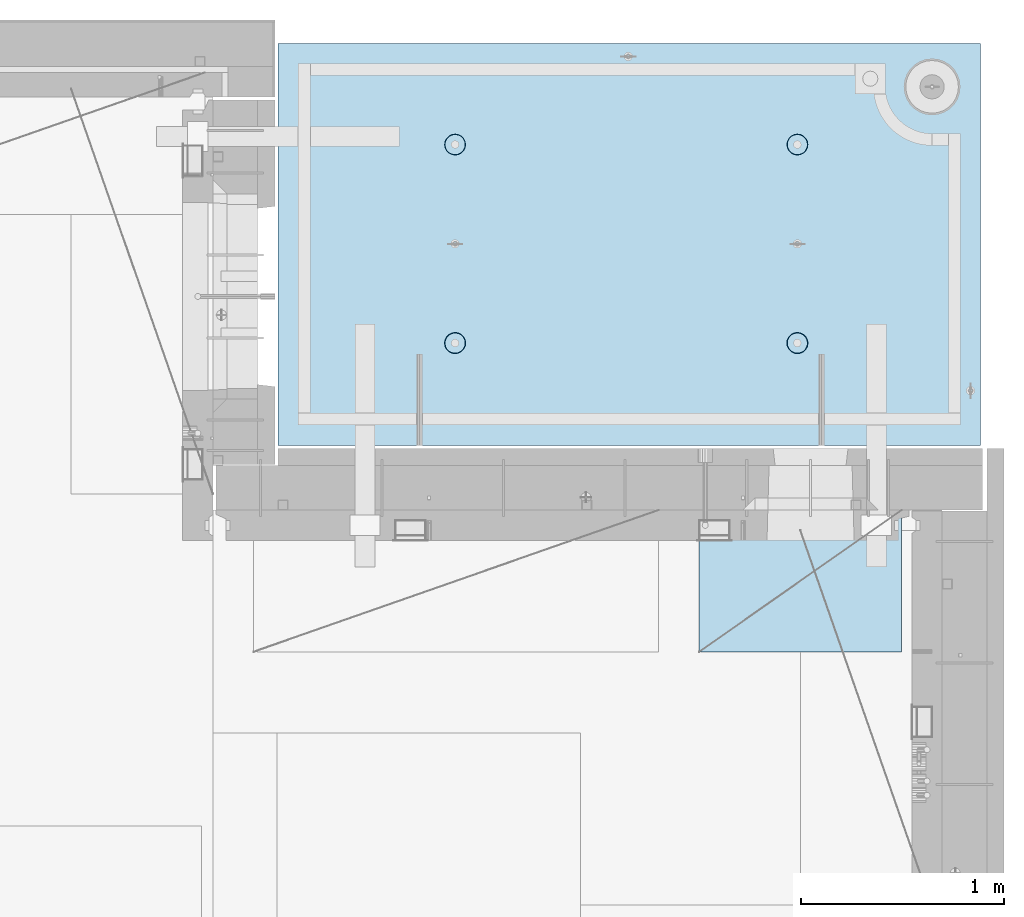
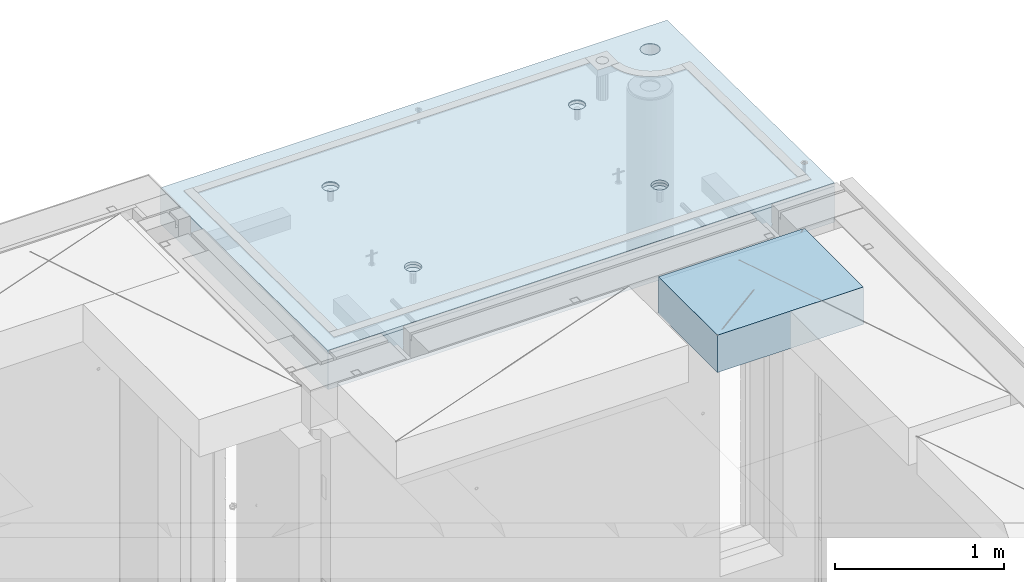
# One storey, part 203 of 341: 2 slabs, 1 plate, 2 elements without a shape of their own.
"""IFC2X3 building model written with IfcOpenShell, lengths in millimetres."""

from ifc_helpers import new_model, si_unit, frame, origin_with_axes, place, context, subcontext, project, spatial, faceted_brep, material, type_object, element, aggregate, save


model = new_model("IFC2X3")

# Units and contexts
model_context = context("Model", 3, precision=1e-05, world=origin_with_axes())
body_context = subcontext(model_context, "Body", "Model", "MODEL_VIEW")
ifc_project = project(units=[si_unit("LENGTHUNIT", "METRE", prefix="MILLI"), si_unit("AREAUNIT", "SQUARE_METRE"), si_unit("VOLUMEUNIT", "CUBIC_METRE"), si_unit("MASSUNIT", "GRAM", prefix="KILO"), si_unit("TIMEUNIT", "SECOND"), si_unit("PLANEANGLEUNIT", "RADIAN"), si_unit("SOLIDANGLEUNIT", "STERADIAN"), si_unit("THERMODYNAMICTEMPERATUREUNIT", "DEGREE_CELSIUS"), si_unit("LUMINOUSINTENSITYUNIT", "LUMEN")], contexts=[model_context])

# Site, building, storey
site_placement = place(None, origin_with_axes())
site = spatial("IfcSite", under=ifc_project, at=site_placement, CompositionType="ELEMENT")
building_placement = place(site_placement, origin_with_axes())
building = spatial("IfcBuilding", under=site, at=building_placement, CompositionType="ELEMENT")
storey_placement = place(building_placement, origin_with_axes())
storey = spatial("IfcBuildingStorey", under=building, at=storey_placement, Name="5", CompositionType="ELEMENT", Elevation=0.0)

# Assembly, slabs
assembly_1_placement = place(storey_placement, origin_with_axes())
assembly_1 = element("IfcElementAssembly", 1, at=assembly_1_placement, inside=storey, AssemblyPlace="NOTDEFINED", PredefinedType="REINFORCEMENT_UNIT")
ifc_material_1 = material(Name="CONCRETE/C35/45")
slab_type_1 = type_object("IfcSlabType", PredefinedType="NOTDEFINED")
slab_1_placement = place(assembly_1_placement, frame((31779.9998568133, 20899.9965573523, 96717.5), z_axis=(0.0, 1.0, 0.0), x_axis=(1.0, 0.0, 0.0)))
slab_1 = element("IfcSlab", 2, at=slab_1_placement, type_object=slab_type_1, material=ifc_material_1, PredefinedType="FLOOR", context=body_context, shape_type="Brep", body=[
    faceted_brep([(3287.06232936882, 9.55874156874779, 1751.46731182328), (3287.06232936882, 12.4999999999563, 1751.46731182328), (3278.5399580536, 12.4999999999563, 1734.74121634823), (3278.5399580536, 9.3480858430994, 1734.74121634823), (3265.26605352866, 12.4999999999563, 1721.46731182328), (3265.26605352866, 9.18090851265879, 1721.46731182328), (3248.5399580536, 12.4999999999563, 1712.94494050807), (3248.5399580536, 9.07357405936637, 1712.94494050807), (3229.99893839111, 12.4999999999563, 1710.00833148578), (3229.99893839111, 9.03658912732499, 1710.00833148578), (3211.45791872861, 12.4999999999563, 1712.94494050807), (3211.45791872861, 9.07357405936637, 1712.94494050807), (3194.73182325356, 12.4999999999563, 1721.46731182328), (3194.73182325356, 9.18090851267334, 1721.46731182328), (3181.45791872861, 12.4999999999563, 1734.74121634823), (3181.45791872861, 9.3480858430994, 1734.74121634823), (3172.9355474134, 12.4999999999563, 1751.46731182328), (3172.9355474134, 9.55874156874779, 1751.46731182328), (3169.99893839111, 12.4999999999563, 1770.00833148578), (3169.99893839111, 9.79225523948844, 1770.00833148578), (3172.9355474134, 12.4999999999563, 1788.54935114827), (3172.9355474134, 10.0257689102291, 1788.54935114827), (3181.45791872861, 12.4999999999563, 1805.27544662332), (3181.45791872861, 10.236424635892, 1805.27544662332), (3194.73182325356, 12.4999999999563, 1818.54935114827), (3194.73182325356, 10.4036019663181, 1818.54935114827), (3211.45791872861, 12.4999999999563, 1827.07172246349), (3211.45791872861, 10.5109364196105, 1827.07172246349), (3229.99893839111, 12.4999999999563, 1830.00833148578), (3229.99893839111, 10.5479213516664, 1830.00833148578), (3248.5399580536, 12.4999999999563, 1827.07172246349), (3248.5399580536, 10.5109364196105, 1827.07172246349), (3265.26605352866, 12.4999999999563, 1818.54935114827), (3265.26605352866, 10.4036019663181, 1818.54935114827), (3278.5399580536, 12.4999999999563, 1805.27544662332), (3278.5399580536, 10.2364246358775, 1805.27544662332), (3287.06232936882, 12.4999999999563, 1788.54935114827), (3287.06232936882, 10.0257689102291, 1788.54935114827), (3289.99893839111, 12.4999999999563, 1770.00833148578), (3289.99893839111, 9.79225523948844, 1770.00833148578), (7.41420080885291e-08, 12.4999999999927, 0.0), (-7.41420080885291e-08, -12.5, -3.63797880709171e-12), (0.0, 12.5, 1985.00366210938), (3470.0, 12.5, 0.0), (3470.00000000004, 12.4999999999563, 1985.00366210935), (3470.0, -12.5, 0.0), (2614.71871715545, -5.93617388149141, 521.168755308547), (2613.67503600632, 12.4999999999709, 520.829642746605), (2616.18047624359, 12.4999999999709, 505.010915653602), (2617.28998057371, -6.13967274603783, 505.010915653602), (2607.28293696061, -5.7526757610467, 535.738532951145), (2606.40396524136, 12.4999999999709, 535.099922616191), (2595.7125242481, -5.60710538028798, 547.296842506817), (2595.0790070157, 12.4999999999709, 546.424880841845), (2581.14006820649, -5.51366887726181, 554.715714533479), (2580.80872714612, 12.4999999999709, 553.695951606805), (2564.99000005311, -5.48147745869937, 557.271717883286), (2564.99000005311, 12.4999999999709, 556.201391844079), (2548.83993189974, -5.51366887726181, 554.715714533479), (2549.17127296011, 12.4999999999709, 553.695951606805), (2534.26747585813, -5.60710538028798, 547.296842506817), (2534.90099309052, 12.4999999999709, 546.424880841845), (2522.69706314561, -5.75267576103215, 535.738532951145), (2523.57603486487, 12.4999999999709, 535.099922616191), (2515.26128295077, -5.93617388147686, 521.168755308547), (2516.30496409991, 12.4999999999709, 520.829642746605), (2512.69001953251, -6.13967274603783, 505.010915653602), (2513.79952386263, 12.4999999999709, 505.010915653602), (2515.23823726424, -6.34326591769059, 488.84558800119), (2516.30496409991, 12.4999999999709, 489.192188560599), (2522.65977443627, -6.52701093736687, 474.256206522903), (2523.57603486487, 12.4999999999709, 474.921908691009), (2534.2301871423, -6.67288650246337, 462.673665286093), (2534.90099309052, 12.4999999999709, 463.596950465359), (2548.81688620273, -6.76656990486663, 455.235189411429), (2549.17127296011, 12.4999999999709, 456.325879700398), (2564.99000005311, -6.79885563062271, 452.67169805654), (2564.99000005311, 12.4999999999709, 453.820439463125), (2581.16311390349, -6.76656990486663, 455.235189411429), (2580.80872714612, 12.4999999999709, 456.325879700398), (2595.74981296392, -6.67288650246337, 462.673665286093), (2595.07900701571, 12.4999999999709, 463.596950465359), (2607.32022566996, -6.52701093736687, 474.256206522903), (2606.40396524136, 12.4999999999709, 474.921908691009), (2614.74176284199, -6.34326591769059, 488.84558800119), (2613.67503600632, 12.4999999999709, 489.192188560599), (924.718717121814, -5.93617388307757, 521.168755181017), (923.675035972585, 12.4999999999854, 520.829642619046), (926.180476209858, 12.4999999999854, 505.010915526043), (927.289980540074, -6.13967274762399, 505.010915526043), (917.282936926953, -5.75267576263286, 535.738532823641), (916.403965207624, 12.4999999999854, 535.099922488633), (905.712524214421, -5.60710538187413, 547.296842379335), (905.07900698197, 12.4999999999854, 546.424880714287), (891.140068172776, -5.51366887886252, 554.715714406011), (890.808727112384, 12.4999999999854, 553.695951479247), (874.990000019381, -5.48147746030008, 557.271717755822), (874.990000019381, 12.4999999999854, 556.20139171652), (858.839931865987, -5.51366887886252, 554.715714406011), (859.171272926378, 12.4999999999854, 553.695951479247), (844.267475824341, -5.60710538187413, 547.296842379335), (844.900993056792, 12.4999999999854, 546.424880714287), (832.697063111809, -5.75267576263286, 535.738532823641), (833.576034831138, 12.4999999999854, 535.099922488633), (825.261282916948, -5.93617388307757, 521.168755181017), (826.304964066177, 12.4999999999854, 520.829642619046), (822.690019498688, -6.13967274762399, 505.010915526043), (823.799523828904, 12.4999999999854, 505.010915526043), (825.238237230413, -6.34326591927675, 488.845587873602), (826.304964066174, 12.4999999999854, 489.19218843304), (832.659774402466, -6.52701093895303, 474.25620639529), (833.576034831141, 12.4999999999854, 474.921908563454), (844.230187108518, -6.67288650404953, 462.673665158458), (844.900993056788, 12.4999999999854, 463.5969503378), (858.816886168974, -6.76656990646734, 455.23518928378), (859.171272926378, 12.4999999999854, 456.32587957284), (874.990000019381, -6.79885563222342, 452.671697928887), (874.990000019381, 12.4999999999854, 453.820439335566), (891.163113869789, -6.76656990646734, 455.23518928378), (890.808727112384, 12.4999999999854, 456.32587957284), (905.749812930244, -6.67288650404953, 462.673665158458), (905.079006981974, 12.4999999999854, 463.5969503378), (917.320225636297, -6.52701093895303, 474.25620639529), (916.403965207621, 12.4999999999854, 474.921908563454), (924.741762808349, -6.34326591927675, 488.845587873602), (923.675035972588, 12.4999999999854, 489.19218843304), (924.02016693788, 6.4034111394576, 1500.93361352766), (923.67503595199, 12.4999999999854, 1500.82147367257), (926.18047618926, 12.4999999999854, 1485.00274657956), (926.555311256641, 6.20277086795249, 1485.00274657956), (916.688838773403, 6.58433162167785, 1515.29872631776), (916.403965187026, 12.4999999999854, 1515.09175354215), (905.280958178348, 6.7278571434581, 1526.69467377167), (905.079006961372, 12.4999999999854, 1526.4167117678), (890.913204613287, 6.81998112349538, 1534.0093312807), (890.808727091786, 12.4999999999854, 1533.68778253277), (874.989999998783, 6.85172034216521, 1536.52942989253), (874.989999998783, 12.4999999999854, 1536.19322277004), (859.066795384279, 6.81998112349538, 1534.0093312807), (859.17127290578, 12.4999999999854, 1533.68778253277), (844.699041819218, 6.7278571434581, 1526.69467377167), (844.900993036194, 12.4999999999854, 1526.4167117678), (833.291161224162, 6.58433162167785, 1515.29872631776), (833.57603481054, 12.4999999999854, 1515.09175354215), (825.959833059685, 6.4034111394576, 1500.93361352766), (826.304964045576, 12.4999999999854, 1500.82147367257), (823.424688740924, 6.20277086795249, 1485.00274657956), (823.799523808306, 12.4999999999854, 1485.00274657956), (825.93711110095, 6.00203761411831, 1469.06449681953), (826.304964045576, 12.4999999999854, 1469.18401948656), (833.254396317472, 5.82087370089721, 1454.68005557312), (833.57603481054, 12.4999999999854, 1454.91373961698), (844.66227690614, 5.67704728177341, 1443.26021682579), (844.90099303619, 12.4999999999854, 1443.58878139132), (859.044073415214, 5.58467987058975, 1435.9262308483), (859.17127290578, 12.4999999999854, 1436.31771062636), (874.989999998783, 5.55284766948898, 1433.39874941703), (874.989999998783, 12.4999999999854, 1433.81227038909), (890.935926582351, 5.58467987058975, 1435.9262308483), (890.808727091786, 12.4999999999854, 1436.31771062636), (905.317723091426, 5.67704728177341, 1443.26021682579), (905.079006961376, 12.4999999999854, 1443.58878139132), (916.725603680094, 5.82087370089721, 1454.68005557312), (916.403965187026, 12.4999999999854, 1454.91373961698), (924.042888896616, 6.00203761411831, 1469.06449681953), (923.67503595199, 12.4999999999854, 1469.18401948656), (2564.9899999698, 12.4999999999709, 1433.81227048016), (2564.9899999698, 5.55284767062403, 1433.39874950818), (2580.93592655335, 5.5846798717248, 1435.92623093945), (2580.8087270628, 12.4999999999709, 1436.31771071744), (2549.17127287679, 12.4999999999709, 1436.31771071744), (2549.04407338624, 5.5846798717248, 1435.92623093945), (2534.9009930072, 12.4999999999709, 1443.5887814824), (2534.66227687719, 5.67704728290846, 1443.26021691693), (2523.57603478155, 12.4999999999709, 1454.91373970805), (2523.25439628854, 5.82087370203226, 1454.68005566423), (2516.30496401659, 12.4999999999709, 1469.18401957764), (2515.93711107203, 6.00203761523881, 1469.06449691063), (2513.79952377931, 12.4999999999709, 1485.00274667064), (2513.424688712, 6.20277086908754, 1485.00274667064), (2516.30496401659, 12.4999999999709, 1500.82147376364), (2515.95983303076, 6.40341114059265, 1500.93361361872), (2523.57603478155, 12.4999999999709, 1515.09175363323), (2523.29116119523, 6.5843316228129, 1515.2987264088), (2534.90099300721, 12.4999999999709, 1526.41671185888), (2534.69904179027, 6.72785714459314, 1526.69467386269), (2549.17127287679, 12.4999999999709, 1533.68778262385), (2549.06679535531, 6.81998112463043, 1534.00933137171), (2564.9899999698, 12.4999999999709, 1536.19322286112), (2564.9899999698, 6.85172034330026, 1536.52942998354), (2580.8087270628, 12.4999999999709, 1533.68778262385), (2580.91320458428, 6.81998112463043, 1534.00933137171), (2595.07900693238, 12.4999999999709, 1526.41671185888), (2595.28095814932, 6.72785714459314, 1526.69467386269), (2606.40396515804, 12.4999999999709, 1515.09175363323), (2606.68883874436, 6.5843316228129, 1515.2987264088), (2613.675035923, 12.4999999999709, 1500.82147376364), (2614.02016690883, 6.40341114059265, 1500.93361361872), (2606.72560365105, 5.82087370203226, 1454.68005566423), (2595.3177230624, 5.67704728290846, 1443.26021691693), (2616.55531122759, 6.20277086908754, 1485.00274667064), (2614.04288886756, 6.00203761523881, 1469.06449691063), (2595.07900693239, 12.4999999999709, 1443.5887814824), (2606.40396515804, 12.4999999999709, 1454.91373970805), (2613.675035923, 12.4999999999709, 1469.18401957764), (2616.18047616028, 12.4999999999709, 1485.00274667064)], [[[0, 1, 2, 3]], [[3, 2, 4, 5]], [[5, 4, 6, 7]], [[7, 6, 8, 9]], [[9, 8, 10, 11]], [[11, 10, 12, 13]], [[13, 12, 14, 15]], [[15, 14, 16, 17]], [[17, 16, 18, 19]], [[19, 18, 20, 21]], [[21, 20, 22, 23]], [[23, 22, 24, 25]], [[25, 24, 26, 27]], [[27, 26, 28, 29]], [[29, 28, 30, 31]], [[31, 30, 32, 33]], [[33, 32, 34, 35]], [[35, 34, 36, 37]], [[37, 36, 38, 39]], [[39, 38, 1, 0]], [[40, 41, 42]], [[43, 44, 45]], [[40, 43, 45, 41]], [[46, 47, 48, 49]], [[50, 51, 47, 46]], [[52, 53, 51, 50]], [[54, 55, 53, 52]], [[56, 57, 55, 54]], [[58, 59, 57, 56]], [[59, 58, 60, 61]], [[61, 60, 62, 63]], [[63, 62, 64, 65]], [[65, 64, 66, 67]], [[67, 66, 68, 69]], [[69, 68, 70, 71]], [[71, 70, 72, 73]], [[73, 72, 74, 75]], [[75, 74, 76, 77]], [[78, 79, 77, 76]], [[80, 81, 79, 78]], [[82, 83, 81, 80]], [[84, 85, 83, 82]], [[49, 48, 85, 84]], [[86, 87, 88, 89]], [[90, 91, 87, 86]], [[92, 93, 91, 90]], [[94, 95, 93, 92]], [[96, 97, 95, 94]], [[98, 99, 97, 96]], [[99, 98, 100, 101]], [[101, 100, 102, 103]], [[103, 102, 104, 105]], [[105, 104, 106, 107]], [[107, 106, 108, 109]], [[109, 108, 110, 111]], [[111, 110, 112, 113]], [[113, 112, 114, 115]], [[115, 114, 116, 117]], [[118, 119, 117, 116]], [[120, 121, 119, 118]], [[122, 123, 121, 120]], [[124, 125, 123, 122]], [[89, 88, 125, 124]], [[126, 127, 128, 129]], [[130, 131, 127, 126]], [[132, 133, 131, 130]], [[134, 135, 133, 132]], [[136, 137, 135, 134]], [[138, 139, 137, 136]], [[140, 141, 139, 138]], [[142, 143, 141, 140]], [[143, 142, 144, 145]], [[145, 144, 146, 147]], [[147, 146, 148, 149]], [[149, 148, 150, 151]], [[151, 150, 152, 153]], [[153, 152, 154, 155]], [[155, 154, 156, 157]], [[157, 156, 158, 159]], [[159, 158, 160, 161]], [[162, 163, 161, 160]], [[164, 165, 163, 162]], [[129, 128, 165, 164]], [[166, 167, 168, 169]], [[170, 171, 167, 166]], [[172, 173, 171, 170]], [[174, 175, 173, 172]], [[176, 177, 175, 174]], [[178, 179, 177, 176]], [[180, 181, 179, 178]], [[182, 183, 181, 180]], [[183, 182, 184, 185]], [[185, 184, 186, 187]], [[187, 186, 188, 189]], [[189, 188, 190, 191]], [[191, 190, 192, 193]], [[193, 192, 194, 195]], [[195, 194, 196, 197]], [[44, 42, 41, 45], [3, 5, 7, 9, 11, 13, 15, 17, 19, 21, 23, 25, 27, 29, 31, 33, 35, 37, 39, 0], [198, 199, 168, 167, 171, 173, 175, 177, 179, 181, 183, 185, 187, 189, 191, 193, 195, 197, 200, 201], [162, 160, 158, 156, 154, 152, 150, 148, 146, 144, 142, 140, 138, 136, 134, 132, 130, 126, 129, 164], [122, 120, 118, 116, 114, 112, 110, 108, 106, 104, 102, 100, 98, 96, 94, 92, 90, 86, 89, 124], [82, 80, 78, 76, 74, 72, 70, 68, 66, 64, 62, 60, 58, 56, 54, 52, 50, 46, 49, 84]], [[169, 168, 199, 202]], [[198, 203, 202, 199]], [[201, 204, 203, 198]], [[200, 205, 204, 201]], [[197, 196, 205, 200]], [[43, 40, 42, 44], [34, 32, 30, 28, 26, 24, 22, 20, 18, 16, 14, 12, 10, 8, 6, 4, 2, 1, 38, 36], [194, 192, 190, 188, 186, 184, 182, 180, 178, 176, 174, 172, 170, 166, 169, 202, 203, 204, 205, 196], [131, 133, 135, 137, 139, 141, 143, 145, 147, 149, 151, 153, 155, 157, 159, 161, 163, 165, 128, 127], [91, 93, 95, 97, 99, 101, 103, 105, 107, 109, 111, 113, 115, 117, 119, 121, 123, 125, 88, 87], [51, 53, 55, 57, 59, 61, 63, 65, 67, 69, 71, 73, 75, 77, 79, 81, 83, 85, 48, 47]]]),
])
slab_type_2 = type_object("IfcSlabType", PredefinedType="NOTDEFINED")
slab_2_placement = place(assembly_1_placement, frame((31779.9998568132, 20899.9965573523, 96575.0), z_axis=(-1.19799915409591e-06, 0.999999999999282, 0.0), x_axis=(0.999999999999282, 1.19800000174933e-06, 0.0)))
slab_2 = element("IfcSlab", 3, at=slab_2_placement, type_object=slab_type_2, material=ifc_material_1, PredefinedType="FLOOR", context=body_context, shape_type="Brep", body=[
    faceted_brep([(2959.65048069304, -130.0, 1795.81551698422), (2959.65048069304, 130.000000000015, 1795.81551698422), (2951.52269537287, 130.000000000015, 1783.6488444481), (2951.52269537287, -130.0, 1783.6488444481), (2939.35761686434, 130.000000000015, 1775.51867349706), (2939.35761686434, -130.0, 1775.51867349706), (2925.00726809365, 130.000000000015, 1772.66274895821), (2925.00726809365, -130.0, 1772.66274895821), (2910.65635957491, 130.000000000015, 1775.51585945357), (2910.65635957491, -130.0, 1775.51585945357), (2898.48968703879, 130.000000000015, 1783.64364477374), (2898.48968703879, -130.0, 1783.64364477374), (2890.35951608775, 130.000000000015, 1795.80872328227), (2890.35951608775, -130.0, 1795.80872328227), (2887.5035915489, 130.000000000015, 1810.15907205296), (2887.5035915489, -130.0, 1810.15907205296), (2890.35670204427, 130.000000000015, 1824.5099805717), (2890.35670204427, -130.0, 1824.5099805717), (2898.48448736444, 130.000000000015, 1836.67665310783), (2898.48448736444, -130.0, 1836.67665310783), (2910.64956587296, 130.000000000015, 1844.80682405887), (2910.64956587296, -130.0, 1844.80682405887), (2924.99991464366, 130.000000000015, 1847.66274859772), (2924.99991464366, -130.0, 1847.66274859772), (2939.3508231624, 130.000000000015, 1844.80963810235), (2939.3508231624, -130.0, 1844.80963810235), (2951.51749569851, 130.000000000015, 1836.68185278219), (2951.51749569851, -130.0, 1836.68185278219), (2959.64766664955, 130.000000000015, 1824.51677427365), (2959.64766664955, -130.0, 1824.51677427365), (2962.50359118841, 130.000000000015, 1810.16642550296), (2962.50359118841, -130.0, 1810.16642550296), (3470.0, -130.0, -2.20097717829049e-09), (0.0, -130.0, -3.63797880709171e-12), (0.0, 130.0, -1.81898940354586e-12), (3470.0, 130.0, -2.20097717829049e-09), (3470.00048828125, -130.0, 1985.00366210938), (3470.00048828125, 130.0, 1985.00366210938), (0.000559809086553287, -130.0, 1985.00366210938), (0.000559809086553287, 130.0, 1985.00366210938), (890.443701616427, -110.0, 1437.44815412734), (904.382128602592, -110.0, 1444.55010256952), (915.443737652884, -110.0, 1455.61166772744), (922.54574140269, -110.0, 1469.55006653296), (924.992946242415, -110.0, 1485.00091139648), (922.545802711662, -110.0, 1500.4517659704), (915.443854269477, -110.0, 1514.39019295657), (904.382289111563, -110.0, 1525.45180200686), (890.44389030604, -110.0, 1532.55380575666), (874.993045442512, -110.0, 1535.00101059639), (859.5421908686, -110.0, 1532.55386706564), (845.603763882435, -110.0, 1525.45191862345), (834.542154832139, -110.0, 1514.39035346554), (827.440151082337, -110.0, 1500.45195466001), (824.992946242612, -110.0, 1485.00110979649), (827.440089773365, -110.0, 1469.55025522257), (834.542038215546, -110.0, 1455.61182823641), (845.603603373464, -110.0, 1444.55021918611), (859.542002178987, -110.0, 1437.44821543631), (874.992847042511, -110.0, 1435.00101059658), (923.678013579975, -130.0, 1500.81964109834), (926.183422432889, -130.0, 1485.00090903458), (916.406971127264, -130.0, 1515.08993539371), (905.082035370349, -130.0, 1526.41491608806), (890.811769926597, -130.0, 1533.68601516524), (874.993047804415, -130.0, 1536.19148678686), (859.174315740653, -130.0, 1533.68607793395), (844.904021445287, -130.0, 1526.41503548124), (833.579040750941, -130.0, 1515.09009972432), (826.307941673756, -130.0, 1500.81983428057), (823.802470052138, -130.0, 1485.00111215839), (826.307878905049, -130.0, 1469.18238009463), (833.578921357763, -130.0, 1454.91208579926), (844.903857114674, -130.0, 1443.58710510491), (859.17412255843, -130.0, 1436.31600602773), (874.992844680608, -130.0, 1433.81053440611), (890.811576744374, -130.0, 1436.31594325902), (905.081871039736, -130.0, 1443.58698571173), (916.406851734086, -130.0, 1454.91192146865), (923.677950811267, -130.0, 1469.1821869124), (890.441757333232, -110.0, 457.456323075745), (904.380184319398, -110.0, 464.558271517926), (915.44179336969, -110.0, 475.619836675844), (922.543797119495, -110.0, 489.558235481371), (924.991001959221, -110.0, 505.009080344891), (922.543858428468, -110.0, 520.459934918807), (915.441909986286, -110.0, 534.398361904972), (904.380344828369, -110.0, 545.459970955264), (890.441946022846, -110.0, 552.56197470507), (874.991101159318, -110.0, 555.009179544795), (859.540246585406, -110.0, 552.562036014042), (845.60181959924, -110.0, 545.460087571857), (834.540210548948, -110.0, 534.398522413943), (827.438206799143, -110.0, 520.46012360842), (824.991001959417, -110.0, 505.009278744892), (827.43814549017, -110.0, 489.558424170984), (834.540093932352, -110.0, 475.619997184815), (845.601659090269, -110.0, 464.558388134519), (859.540057895792, -110.0, 457.456384384717), (874.99090275932, -110.0, 455.009179544992), (923.676069296784, -130.0, 520.827810046754), (926.181478149694, -130.0, 505.009077982988), (916.405026844073, -130.0, 535.098104342116), (905.080091087159, -130.0, 546.423085036466), (890.809825643402, -130.0, 553.694184113647), (874.991103521224, -130.0, 556.199655735272), (859.172371457458, -130.0, 553.694246882354), (844.902077162096, -130.0, 546.423204429644), (833.57709646775, -130.0, 535.098268672729), (826.305997390566, -130.0, 520.828003228977), (823.800525768944, -130.0, 505.009281106795), (826.305934621854, -130.0, 489.190549043033), (833.576977074568, -130.0, 474.920254747667), (844.901912831479, -130.0, 463.595274053321), (859.172178275239, -130.0, 456.32417497614), (874.990900397414, -130.0, 453.818703354518), (890.809632461183, -130.0, 456.324112207432), (905.079926756542, -130.0, 463.595154660143), (916.404907450891, -130.0, 474.920090417054), (923.676006528072, -130.0, 489.19035586081), (2580.44175736364, -110.0, 457.452970243303), (2594.3801843498, -110.0, 464.554918685484), (2605.4417934001, -110.0, 475.616483843402), (2612.54379714991, -110.0, 489.554882648928), (2614.99100198962, -110.0, 505.005727512449), (2612.54385845887, -110.0, 520.456582086365), (2605.44191001669, -110.0, 534.39500907253), (2594.38034485878, -110.0, 545.456618122822), (2580.44194605325, -110.0, 552.558621872628), (2564.99110118972, -110.0, 555.005826712353), (2549.54024661581, -110.0, 552.5586831816), (2535.60181962965, -110.0, 545.456734739415), (2524.54021057935, -110.0, 534.395169581501), (2517.43820682954, -110.0, 520.456770775978), (2514.99100198982, -110.0, 505.00592591245), (2517.43814552058, -110.0, 489.555071338542), (2524.54009396276, -110.0, 475.616644352373), (2535.60165912067, -110.0, 464.555035302077), (2549.5400579262, -110.0, 457.453031552275), (2564.99090278973, -110.0, 455.00582671255), (2613.67606932719, -130.0, 520.824457214312), (2616.1814781801, -130.0, 505.005725150546), (2606.40502687448, -130.0, 535.094751509674), (2595.08009111756, -130.0, 546.419732204024), (2580.80982567381, -130.0, 553.690831281205), (2564.99110355163, -130.0, 556.19630290283), (2549.17237148786, -130.0, 553.690894049912), (2534.9020771925, -130.0, 546.419851597202), (2523.57709649815, -130.0, 535.094915840287), (2516.30599742097, -130.0, 520.824650396535), (2513.80052579935, -130.0, 505.005928274353), (2516.30593465226, -130.0, 489.187196210591), (2523.57697710497, -130.0, 474.916901915225), (2534.90191286189, -130.0, 463.591921220879), (2549.17217830564, -130.0, 456.320822143698), (2564.99090042782, -130.0, 453.815350522076), (2580.80963249159, -130.0, 456.32075937499), (2595.07992678695, -130.0, 463.591801827701), (2606.4049074813, -130.0, 474.916737584612), (2613.67600655848, -130.0, 489.187003028368), (2580.44370158411, -110.0, 1437.44480125841), (2594.38212857028, -110.0, 1444.5467497006), (2605.44373762057, -110.0, 1455.60831485851), (2612.54574137038, -110.0, 1469.54671366404), (2614.9929462101, -110.0, 1484.99755852756), (2612.54580267935, -110.0, 1500.44841310148), (2605.44385423717, -110.0, 1514.38684008764), (2594.38228907925, -110.0, 1525.44844913793), (2580.44389027373, -110.0, 1532.55045288774), (2564.9930454102, -110.0, 1534.99765772746), (2549.54219083629, -110.0, 1532.55051419671), (2535.60376385012, -110.0, 1525.44856575453), (2524.54215479983, -110.0, 1514.38700059661), (2517.44015105002, -110.0, 1500.44860179109), (2514.99294621029, -110.0, 1484.99775692756), (2517.44008974105, -110.0, 1469.54690235365), (2524.54203818323, -110.0, 1455.60847536748), (2535.60360334115, -110.0, 1444.54686631719), (2549.54200214667, -110.0, 1437.44486256739), (2564.9928470102, -110.0, 1434.99765772766), (2613.67801354766, -130.0, 1500.81628822942), (2616.18342240057, -130.0, 1484.99755616566), (2606.40697109495, -130.0, 1515.08658252479), (2595.08203533804, -130.0, 1526.41156321914), (2580.81176989429, -130.0, 1533.68266229632), (2564.9930477721, -130.0, 1536.18813391794), (2549.17431570834, -130.0, 1533.68272506502), (2534.90402141297, -130.0, 1526.41168261231), (2523.57904071863, -130.0, 1515.0867468554), (2516.30794164144, -130.0, 1500.81648141164), (2513.80247001983, -130.0, 1484.99775928947), (2516.30787887274, -130.0, 1469.1790272257), (2523.57892132545, -130.0, 1454.90873293034), (2534.90385708237, -130.0, 1443.58375223599), (2549.17412252611, -130.0, 1436.31265315881), (2564.99284464829, -130.0, 1433.80718153719), (2580.81157671207, -130.0, 1436.3125903901), (2595.08187100743, -130.0, 1443.58363284281), (2606.40685170178, -130.0, 1454.90856859972), (2613.67795077896, -130.0, 1469.17883404348), (3278.54339977372, -130.0, 1734.73471172154), (3265.26946891338, -130.0, 1721.46083353204), (3248.54335652997, -130.0, 1712.93849540142), (3230.00233104128, -130.0, 1710.00192316452), (3211.46131720506, -130.0, 1712.93856897219), (3194.73523863843, -130.0, 1721.46097347196), (3181.46136044892, -130.0, 1734.73490433231), (3172.9390223183, -130.0, 1751.46101671571), (3170.0024500814, -130.0, 1770.0020422044), (3172.93909588907, -130.0, 1788.54305604063), (3181.46150038884, -130.0, 1805.26913460726), (3194.73543124919, -130.0, 1818.54301279676), (3211.46154363259, -130.0, 1827.06535092738), (3230.00256912128, -130.0, 1830.00192316428), (3248.54358295751, -130.0, 1827.06527735662), (3265.26966152415, -130.0, 1818.54287285685), (3278.54353971364, -130.0, 1805.2689419965), (3287.06587784427, -130.0, 1788.5428296131), (3290.00245008117, -130.0, 1770.0018041244), (3287.0658042735, -130.0, 1751.46079028817), (3278.54353971364, 130.0, 1805.2689419965), (3287.06587784427, 130.0, 1788.5428296131), (3265.26966152415, 130.0, 1818.54287285685), (3248.54358295751, 130.0, 1827.06527735662), (3230.00256912128, 130.0, 1830.00192316428), (3211.46154363259, 130.0, 1827.06535092738), (3194.73543124919, 130.0, 1818.54301279676), (3181.46150038884, 130.0, 1805.26913460726), (3172.93909588907, 130.0, 1788.54305604063), (3170.0024500814, 130.0, 1770.0020422044), (3172.9390223183, 130.0, 1751.46101671571), (3181.46136044892, 130.0, 1734.73490433231), (3194.73523863843, 130.0, 1721.46097347196), (3211.46131720506, 130.0, 1712.93856897219), (3230.00233104128, 130.0, 1710.00192316452), (3248.54335652997, 130.0, 1712.93849540142), (3265.26946891338, 130.0, 1721.46083353204), (3278.54339977372, 130.0, 1734.73471172154), (3287.0658042735, 130.0, 1751.46079028817), (3290.00245008117, 130.0, 1770.0018041244)], [[[0, 1, 2, 3]], [[3, 2, 4, 5]], [[5, 4, 6, 7]], [[7, 6, 8, 9]], [[9, 8, 10, 11]], [[11, 10, 12, 13]], [[13, 12, 14, 15]], [[15, 14, 16, 17]], [[17, 16, 18, 19]], [[19, 18, 20, 21]], [[21, 20, 22, 23]], [[23, 22, 24, 25]], [[25, 24, 26, 27]], [[27, 26, 28, 29]], [[29, 28, 30, 31]], [[31, 30, 1, 0]], [[32, 33, 34, 35]], [[36, 32, 35, 37]], [[38, 36, 37, 39]], [[33, 38, 39, 34]], [[40, 41, 42, 43, 44, 45, 46, 47, 48, 49, 50, 51, 52, 53, 54, 55, 56, 57, 58, 59]], [[60, 45, 44, 61]], [[62, 46, 45, 60]], [[63, 47, 46, 62]], [[64, 48, 47, 63]], [[65, 49, 48, 64]], [[66, 50, 49, 65]], [[67, 51, 50, 66]], [[68, 52, 51, 67]], [[69, 53, 52, 68]], [[70, 54, 53, 69]], [[71, 55, 54, 70]], [[72, 56, 55, 71]], [[73, 57, 56, 72]], [[74, 58, 57, 73]], [[75, 59, 58, 74]], [[76, 40, 59, 75]], [[77, 41, 40, 76]], [[78, 42, 41, 77]], [[79, 43, 42, 78]], [[61, 44, 43, 79]], [[80, 81, 82, 83, 84, 85, 86, 87, 88, 89, 90, 91, 92, 93, 94, 95, 96, 97, 98, 99]], [[100, 85, 84, 101]], [[102, 86, 85, 100]], [[103, 87, 86, 102]], [[104, 88, 87, 103]], [[105, 89, 88, 104]], [[106, 90, 89, 105]], [[107, 91, 90, 106]], [[108, 92, 91, 107]], [[109, 93, 92, 108]], [[110, 94, 93, 109]], [[111, 95, 94, 110]], [[112, 96, 95, 111]], [[113, 97, 96, 112]], [[114, 98, 97, 113]], [[115, 99, 98, 114]], [[116, 80, 99, 115]], [[117, 81, 80, 116]], [[118, 82, 81, 117]], [[119, 83, 82, 118]], [[101, 84, 83, 119]], [[120, 121, 122, 123, 124, 125, 126, 127, 128, 129, 130, 131, 132, 133, 134, 135, 136, 137, 138, 139]], [[140, 125, 124, 141]], [[142, 126, 125, 140]], [[143, 127, 126, 142]], [[144, 128, 127, 143]], [[145, 129, 128, 144]], [[146, 130, 129, 145]], [[147, 131, 130, 146]], [[148, 132, 131, 147]], [[149, 133, 132, 148]], [[150, 134, 133, 149]], [[151, 135, 134, 150]], [[152, 136, 135, 151]], [[153, 137, 136, 152]], [[154, 138, 137, 153]], [[155, 139, 138, 154]], [[156, 120, 139, 155]], [[157, 121, 120, 156]], [[158, 122, 121, 157]], [[159, 123, 122, 158]], [[141, 124, 123, 159]], [[160, 161, 162, 163, 164, 165, 166, 167, 168, 169, 170, 171, 172, 173, 174, 175, 176, 177, 178, 179]], [[180, 165, 164, 181]], [[182, 166, 165, 180]], [[183, 167, 166, 182]], [[184, 168, 167, 183]], [[185, 169, 168, 184]], [[186, 170, 169, 185]], [[187, 171, 170, 186]], [[188, 172, 171, 187]], [[189, 173, 172, 188]], [[190, 174, 173, 189]], [[191, 175, 174, 190]], [[192, 176, 175, 191]], [[193, 177, 176, 192]], [[194, 178, 177, 193]], [[195, 179, 178, 194]], [[196, 160, 179, 195]], [[197, 161, 160, 196]], [[198, 162, 161, 197]], [[199, 163, 162, 198]], [[181, 164, 163, 199]], [[32, 36, 38, 33], [3, 5, 7, 9, 11, 13, 15, 17, 19, 21, 23, 25, 27, 29, 31, 0], [198, 197, 196, 195, 194, 193, 192, 191, 190, 189, 188, 187, 186, 185, 184, 183, 182, 180, 181, 199], [158, 157, 156, 155, 154, 153, 152, 151, 150, 149, 148, 147, 146, 145, 144, 143, 142, 140, 141, 159], [118, 117, 116, 115, 114, 113, 112, 111, 110, 109, 108, 107, 106, 105, 104, 103, 102, 100, 101, 119], [78, 77, 76, 75, 74, 73, 72, 71, 70, 69, 68, 67, 66, 65, 64, 63, 62, 60, 61, 79], [200, 201, 202, 203, 204, 205, 206, 207, 208, 209, 210, 211, 212, 213, 214, 215, 216, 217, 218, 219]], [[216, 220, 221, 217]], [[215, 222, 220, 216]], [[214, 223, 222, 215]], [[213, 224, 223, 214]], [[212, 225, 224, 213]], [[211, 226, 225, 212]], [[210, 227, 226, 211]], [[209, 228, 227, 210]], [[208, 229, 228, 209]], [[207, 230, 229, 208]], [[206, 231, 230, 207]], [[205, 232, 231, 206]], [[204, 233, 232, 205]], [[203, 234, 233, 204]], [[202, 235, 234, 203]], [[201, 236, 235, 202]], [[200, 237, 236, 201]], [[219, 238, 237, 200]], [[218, 239, 238, 219]], [[217, 221, 239, 218]], [[37, 35, 34, 39], [26, 24, 22, 20, 18, 16, 14, 12, 10, 8, 6, 4, 2, 1, 30, 28], [220, 222, 223, 224, 225, 226, 227, 228, 229, 230, 231, 232, 233, 234, 235, 236, 237, 238, 239, 221]]]),
])
aggregate(assembly_1, [slab_1, slab_2])

# Assembly, plate
assembly_2_placement = place(storey_placement, origin_with_axes())
assembly_2 = element("IfcElementAssembly", 4, at=assembly_2_placement, inside=storey, Name="Steel Assembly", AssemblyPlace="NOTDEFINED", PredefinedType="NOTDEFINED")
ifc_material_2 = material()
plate_type = type_object("IfcPlateType", PredefinedType="NOTDEFINED")
plate_placement = place(assembly_2_placement, frame((34860.0, 20580.0000000707, 96595.3), z_axis=(0.0, -1.0, 0.0), x_axis=(-1.0, 3.00000001838171e-08, 0.0)))
plate = element("IfcPlate", 5, at=plate_placement, type_object=plate_type, material=ifc_material_2, Name="RE1_1/2", context=body_context, shape_type="Brep", body=[
    faceted_brep([(1.81898940354586e-12, -135.0, 1.81898940354586e-12), (0.0, -135.0, 699.999999999996), (0.0, 135.0, 699.999999999996), (1.81898940354586e-12, 135.0, 1.81898940354586e-12), (999.99951171875, -135.0, 700.0), (999.99951171875, 135.0, 700.0), (1000.0, -135.0, 0.0), (1000.0, 135.0, 0.0)], [[[0, 1, 2, 3]], [[1, 4, 5, 2]], [[4, 6, 7, 5]], [[6, 0, 3, 7]], [[5, 7, 3, 2]], [[6, 4, 1, 0]]]),
])
aggregate(assembly_2, [plate])

save(model, "model.ifc")
